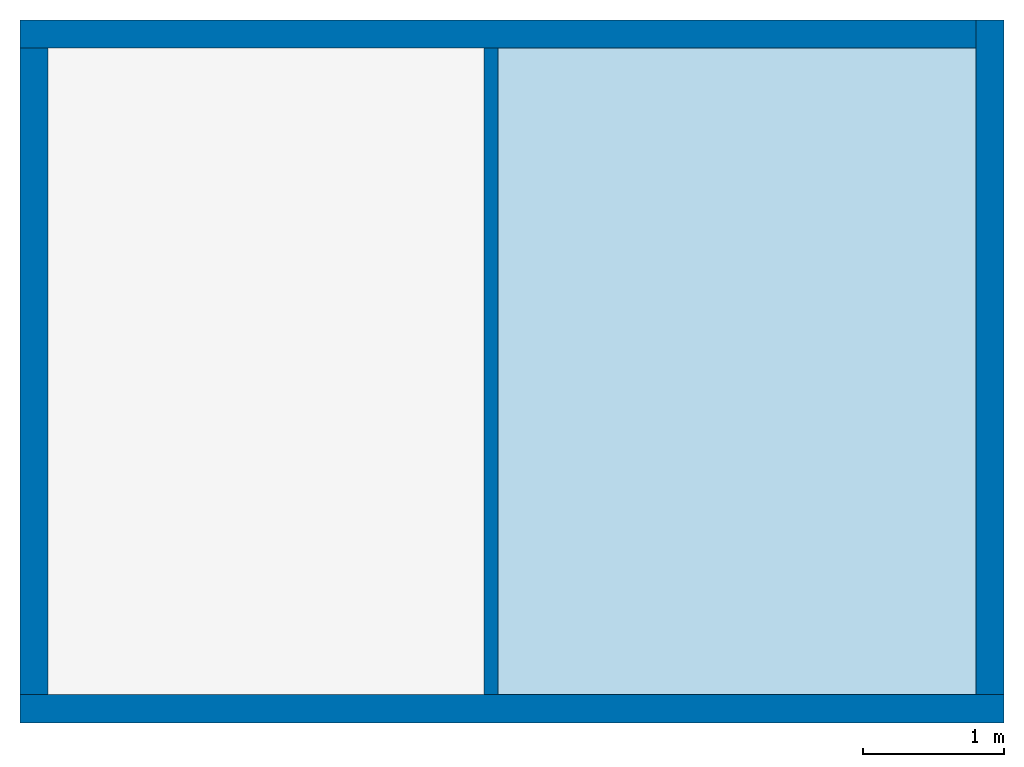
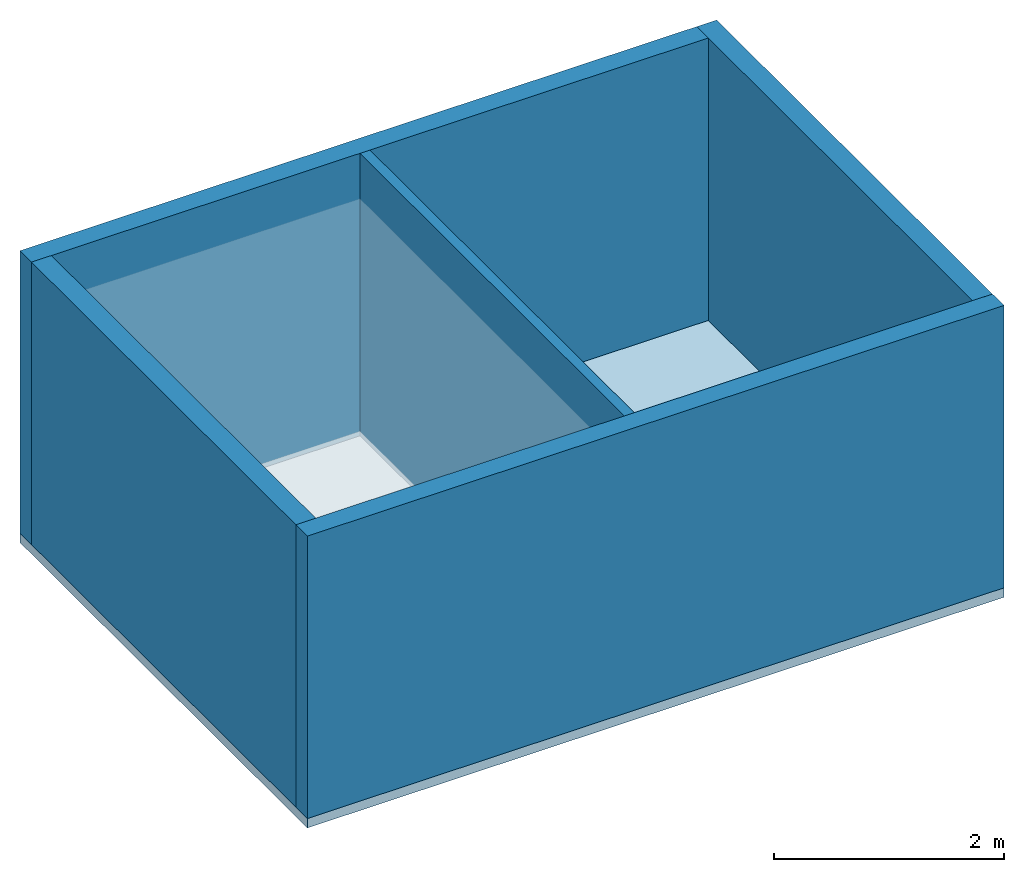
# One storey, part 1 of 2: 5 walls, 1 slab.
"""IFC4 building model written with IfcOpenShell, lengths in metres."""

from ifc_helpers import new_model, entity, si_unit, converted_unit, frame, origin_with_axes, origin_2d_with_axis, place, context, subcontext, project, spatial, line, indexed_curve, outline, extrude, material, layer, layer_set, layer_usage, type_object, element, save


model = new_model("IFC4")

# Units and contexts
model_context = context("Model", 3, precision=1e-05, world=origin_with_axes())
plan_context = context("Plan", 2, precision=1e-05, world=origin_2d_with_axis())
body_context = subcontext(model_context, "Body", "Model", "MODEL_VIEW")
ifc_project = project(units=[si_unit("VOLUMEUNIT", "CUBIC_METRE"), si_unit("LENGTHUNIT", "METRE"), converted_unit("PLANEANGLEUNIT", "degree", entity("IfcReal", 0.0174532925199433), si_unit("PLANEANGLEUNIT", "RADIAN"), dimensions=[0, 0, 0, 0, 0, 0, 0]), si_unit("AREAUNIT", "SQUARE_METRE")], contexts=[model_context, plan_context])

# Site, building, storey
site_placement = place(None, origin_with_axes())
site = spatial("IfcSite", under=ifc_project, at=site_placement)
building_placement = place(site_placement, origin_with_axes())
building = spatial("IfcBuilding", under=site, at=building_placement, Name="Building")
storey_placement = place(building_placement, origin_with_axes())
storey = spatial("IfcBuildingStorey", under=building, at=storey_placement, Name="Storey")

# Slab
ifc_material = material()
ifc_layer_1 = layer(ifc_material, 0.1)
ifc_layer_set_1 = layer_set([ifc_layer_1])
ifc_layer_usage_1 = layer_usage(ifc_layer_set_1, "AXIS3", "POSITIVE", 0.0)
slab_type = type_object("IfcSlabType", Name="SLB-01", PredefinedType="FLOOR", material=ifc_layer_set_1)
slab_placement = place(storey_placement, frame((0.0, 0.0, -0.100000001490116), z_axis=(0.0, 0.0, 1.0), x_axis=(1.0, 0.0, 0.0)))
element("IfcSlab", 1, at=slab_placement, inside=storey, type_object=slab_type, material=ifc_layer_usage_1, Name="Slab", context=body_context, shape_type="SweptSolid", body=[
    extrude(outline(indexed_curve([(0.0, 0.0), (7.0, 0.0), (7.0, 5.0), (0.0, 5.0)], segments=[line(3, 2), line(2, 1), line(1, 4), line(4, 3)], self_intersect=False)), None, (0.0, 0.0, 1.0), 0.1),
])

# Walls
ifc_layer_2 = layer(ifc_material, 0.200000002980232)
ifc_layer_set_2 = layer_set([ifc_layer_2])
ifc_layer_usage_2 = layer_usage(ifc_layer_set_2, "AXIS2", "POSITIVE", 0.0)
wall_type_1 = type_object("IfcWallType", Name="WAL-01", PredefinedType="SOLIDWALL", material=ifc_layer_set_2)
wall_1_placement = place(storey_placement, origin_with_axes())
element("IfcWall", 2, at=wall_1_placement, inside=storey, type_object=wall_type_1, material=ifc_layer_usage_2, Name="Wall", context=body_context, shape_type="SweptSolid", body=[
    extrude(outline(indexed_curve([(0.0, 0.0), (0.0, 0.200000002980232), (7.0, 0.200000002980232), (7.0, 0.0), (0.0, 0.0)], self_intersect=False)), origin_with_axes(), (0.0, 0.0, 1.0), 3.0),
])
ifc_layer_usage_3 = layer_usage(ifc_layer_set_2, "AXIS2", "POSITIVE", 0.0)
wall_2_placement = place(storey_placement, frame((7.0, 0.200000002980232, 0.0), z_axis=(0.0, 0.0, 1.0), x_axis=(7.54979012640431e-08, 0.999999999999997, 0.0)))
element("IfcWall", 3, at=wall_2_placement, inside=storey, type_object=wall_type_1, material=ifc_layer_usage_3, Name="Wall", context=body_context, shape_type="SweptSolid", body=[
    extrude(outline(indexed_curve([(0.0, 0.0), (0.0, 0.200000002980232), (4.799999300639, 0.200000002980232), (4.799999300639, 0.0), (0.0, 0.0)], self_intersect=False)), origin_with_axes(), (0.0, 0.0, 1.0), 3.0),
])
ifc_layer_usage_4 = layer_usage(ifc_layer_set_2, "AXIS2", "POSITIVE", 0.0)
wall_3_placement = place(storey_placement, frame((6.80000162124634, 4.99999904632568, 0.0), z_axis=(0.0, 0.0, 1.0), x_axis=(-0.999999999999924, 3.89414367418765e-07, 0.0)))
element("IfcWall", 4, at=wall_3_placement, inside=storey, type_object=wall_type_1, material=ifc_layer_usage_4, Name="Wall", context=body_context, shape_type="SweptSolid", body=[
    extrude(outline(indexed_curve([(0.0, 0.0), (0.0, 0.200000002980232), (6.80000012341728, 0.200000002980232), (6.80000012341728, 0.0), (0.0, 0.0)], self_intersect=False)), origin_with_axes(), (0.0, 0.0, 1.0), 3.0),
])
ifc_layer_usage_5 = layer_usage(ifc_layer_set_2, "AXIS2", "POSITIVE", 0.0)
wall_4_placement = place(storey_placement, frame((1.43051147460938e-06, 4.80000162124634, 0.0), z_axis=(0.0, 0.0, 1.0), x_axis=(-4.01339264044477e-07, -0.99999999999992, 0.0)))
element("IfcWall", 5, at=wall_4_placement, inside=storey, type_object=wall_type_1, material=ifc_layer_usage_5, Name="Wall", context=body_context, shape_type="SweptSolid", body=[
    extrude(outline(indexed_curve([(0.0, 0.0), (0.0, 0.200000002980232), (4.59999936145299, 0.200000002980232), (4.59999936145299, 0.0), (0.0, 0.0)], self_intersect=False)), origin_with_axes(), (0.0, 0.0, 1.0), 3.0),
])
ifc_layer_3 = layer(ifc_material, 0.100000001490116)
ifc_layer_set_3 = layer_set([ifc_layer_3])
ifc_layer_usage_6 = layer_usage(ifc_layer_set_3, "AXIS2", "POSITIVE", 0.0)
wall_type_2 = type_object("IfcWallType", Name="WAL-02", PredefinedType="SOLIDWALL", material=ifc_layer_set_3)
wall_5_placement = place(storey_placement, frame((3.30065321922302, 4.80000114440918, 0.0), z_axis=(0.0, 0.0, 1.0), x_axis=(-5.2054855359522e-07, -0.999999999999865, 0.0)))
element("IfcWall", 6, at=wall_5_placement, inside=storey, type_object=wall_type_2, material=ifc_layer_usage_6, Name="Wall", context=body_context, shape_type="SweptSolid", body=[
    extrude(outline(indexed_curve([(0.0, 0.0), (0.0, 0.100000001490116), (4.59999998341511, 0.100000001490116), (4.59999998341511, 0.0), (0.0, 0.0)], self_intersect=False)), origin_with_axes(), (0.0, 0.0, 1.0), 3.0),
])

save(model, "model.ifc")
